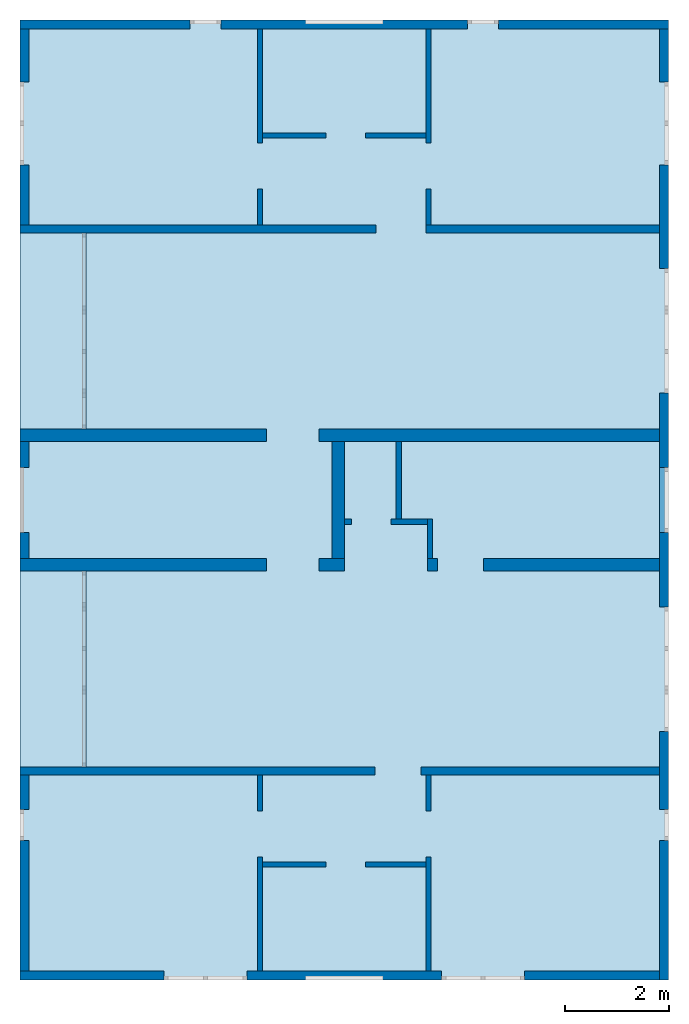
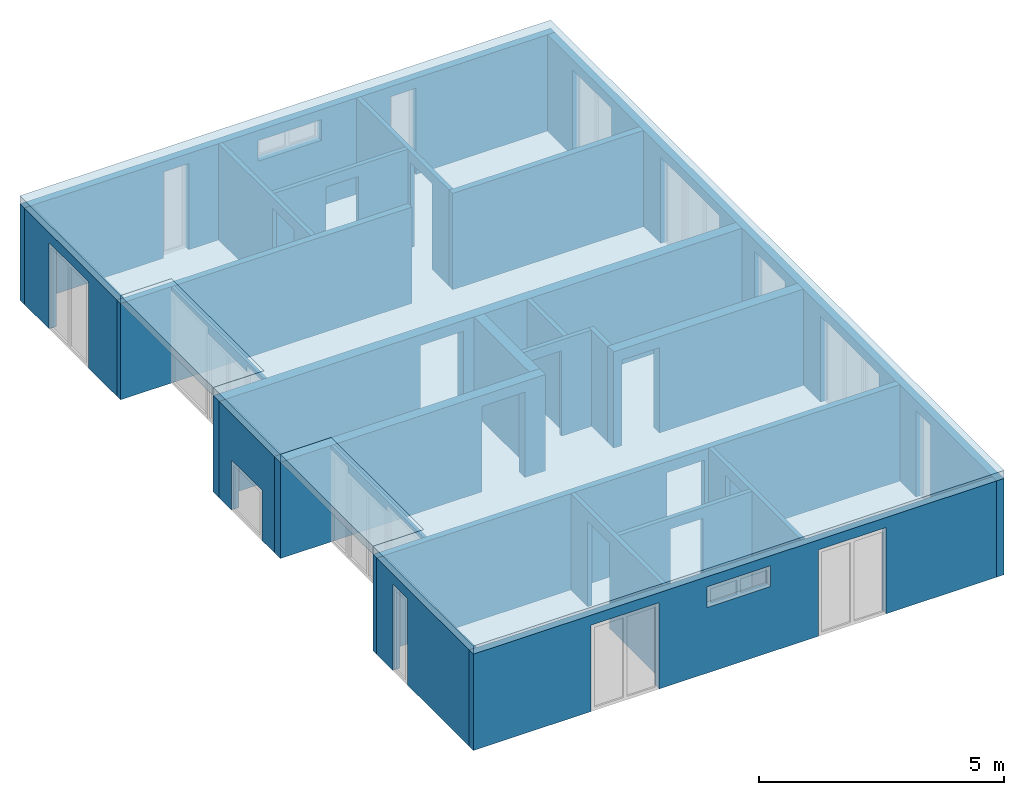
# One storey, part 1 of 8: 24 walls, 3 slabs, 33 openings.
"""IFC2X3 building model written with IfcOpenShell, lengths in millimetres."""

from ifc_helpers import new_model, entity, si_unit, converted_unit, frame, frame_2d, origin, origin_with_axes, place, context, project, spatial, polyline, rectangle, outline, extrude, material, layer, layer_set, layer_usage, element, save


model = new_model("IFC2X3")

# Units and contexts
model_context = context("Model", 3, precision=1e-05, world=origin())
plan_context = context("Plan", 3, precision=1e-05, world=origin())
ifc_project = project(units=[si_unit("LENGTHUNIT", "METRE", prefix="MILLI"), converted_unit("PLANEANGLEUNIT", "DEGREE", entity("IfcPlaneAngleMeasure", 0.0174532925199433), si_unit("PLANEANGLEUNIT", "RADIAN"), dimensions=[0, 0, 0, 0, 0, 0, 0]), si_unit("AREAUNIT", "SQUARE_METRE"), si_unit("VOLUMEUNIT", "CUBIC_METRE")], contexts=[model_context, plan_context])

# Building, storey
building_placement = place(None, origin())
building = spatial("IfcBuilding", under=ifc_project, at=building_placement, CompositionType="ELEMENT")
storey_placement = place(building_placement, frame((0.0, 0.0, 2900.0), z_axis=(0.0, 0.0, 1.0), x_axis=(1.0, 0.0, 0.0)))
storey = spatial("IfcBuildingStorey", under=building, at=storey_placement, Name="OG", CompositionType="ELEMENT", Elevation=2900.0)

# Slabs
ifc_material_1 = material(Name="B25")
ifc_layer_1 = layer(ifc_material_1, 200.0)
ifc_layer_set_1 = layer_set([ifc_layer_1])
ifc_layer_usage_1 = layer_usage(ifc_layer_set_1, "AXIS3", "POSITIVE", 0.0)
slab_1_placement = place(storey_placement, frame((21188.3517822139, 5708.43749999999, 2400.0), z_axis=(0.0, 0.0, 1.0), x_axis=(1.0, 0.0, 0.0)))
element("IfcSlab", 1, at=slab_1_placement, inside=storey, material=ifc_layer_usage_1, PredefinedType="FLOOR", context=model_context, shape_type="SweptSolid", body=[
    extrude(rectangle(XDim=3779.99999999999, YDim=1200.00000000373, at=frame_2d((600.0, -1890.00000000059), x_axis=(-9.85526533984635e-13, -1.0))), origin_with_axes(), (0.0, 0.0, 1.0), 200.0),
])
ifc_material_2 = material(Name="B25")
ifc_layer_2 = layer(ifc_material_2, 200.0)
ifc_layer_set_2 = layer_set([ifc_layer_2])
ifc_layer_usage_2 = layer_usage(ifc_layer_set_2, "AXIS3", "POSITIVE", 0.0)
slab_2_placement = place(storey_placement, frame((21188.3517822102, -811.5625, 2400.0), z_axis=(0.0, 0.0, 1.0), x_axis=(1.0, 0.0, 0.0)))
element("IfcSlab", 2, at=slab_2_placement, inside=storey, material=ifc_layer_usage_2, PredefinedType="FLOOR", context=model_context, shape_type="SweptSolid", body=[
    extrude(rectangle(XDim=3780.0, YDim=1200.0, at=frame_2d((600.000000001863, -1889.99999999941), x_axis=(9.85526533984634e-13, -1.0))), origin_with_axes(), (0.0, 0.0, 1.0), 200.0),
])
ifc_material_3 = material(Name="B25")
ifc_layer_3 = layer(ifc_material_3, 200.0)
ifc_layer_set_3 = layer_set([ifc_layer_3])
ifc_layer_usage_3 = layer_usage(ifc_layer_set_3, "AXIS3", "POSITIVE", 0.0)
slab_3_placement = place(storey_placement, frame((21188.3517822102, -8691.5625, 2400.0), z_axis=(0.0, 0.0, 1.0), x_axis=(1.0, 0.0, 0.0)))
element("IfcSlab", 3, at=slab_3_placement, inside=storey, material=ifc_layer_usage_3, PredefinedType="FLOOR", context=model_context, shape_type="SweptSolid", body=[
    extrude(outline(polyline([(3.72529029846191e-09, 18500.0), (3.72529029846191e-09, 14400.0), (1200.00000000373, 14400.0), (1200.00000000373, 10620.0), (0.0, 10620.0), (0.0, 7880.0), (1200.00000000373, 7880.0), (1200.00000000373, 4100.0), (3.72529029846191e-09, 4100.0), (3.72529029846191e-09, 0.0), (12500.0000000037, 0.0), (12500.0000000037, 18500.0), (3.72529029846191e-09, 18500.0)])), origin_with_axes(), (0.0, 0.0, 1.0), 200.0),
])

# Wall, opening
ifc_material_4 = material(Name="B25")
ifc_layer_4 = layer(ifc_material_4, 150.0)
ifc_layer_set_4 = layer_set([ifc_layer_4])
ifc_layer_usage_4 = layer_usage(ifc_layer_set_4, "AXIS2", "POSITIVE", 0.0)
wall_1_placement = place(storey_placement, frame((21188.3517822139, -4741.5625, 0.0), z_axis=(0.0, 0.0, 1.0), x_axis=(1.0, 0.0, 0.0)))
wall_1 = element("IfcWallStandardCase", 4, at=wall_1_placement, inside=storey, material=ifc_layer_usage_4, context=model_context, shape_type="SweptSolid", body=[
    extrude(rectangle(XDim=12324.9999999553, YDim=150.0, at=frame_2d((6162.49999997765, 75.0), x_axis=(1.0, 0.0))), origin_with_axes(), (0.0, 0.0, 1.0), 2400.0),
])
opening_1_placement = place(wall_1_placement, frame((6840.00089017584, 0.0, 0.0), z_axis=(0.0, 1.0, 0.0), x_axis=(0.0, 0.0, 1.0)))
element("IfcOpeningElement", 5, at=opening_1_placement, cuts=wall_1, ObjectType="Opening", context=model_context, shape_type="SweptSolid", body=[
    extrude(rectangle(XDim=2130.0, YDim=885.000000042997, at=frame_2d((1065.0, 442.500000021499), x_axis=(1.0, 0.0))), origin_with_axes(), (0.0, 0.0, 1.0), 150.0),
])

ifc_material_5 = material(Name="B25")
ifc_layer_5 = layer(ifc_material_5, 240.0)
ifc_layer_set_5 = layer_set([ifc_layer_5])
ifc_layer_usage_5 = layer_usage(ifc_layer_set_5, "AXIS2", "POSITIVE", 0.0)
wall_2_placement = place(storey_placement, frame((27438.3517822107, -571.5625, 0.0), z_axis=(0.0, 0.0, 1.0), x_axis=(-1.0, 0.0, 0.0)))
wall_2 = element("IfcWallStandardCase", 6, at=wall_2_placement, inside=storey, material=ifc_layer_usage_5, context=model_context, shape_type="SweptSolid", body=[
    extrude(rectangle(XDim=6250.0000000005, YDim=240.0, at=frame_2d((3125.00000000025, 120.0), x_axis=(1.0, 0.0))), origin_with_axes(), (0.0, 0.0, 1.0), 2400.0),
])
opening_2_placement = place(wall_2_placement, frame((490.000000000498, 0.0, 0.0), z_axis=(0.0, 1.0, 0.0), x_axis=(0.0, 0.0, 1.0)))
element("IfcOpeningElement", 7, at=opening_2_placement, cuts=wall_2, ObjectType="Opening", context=model_context, shape_type="SweptSolid", body=[
    extrude(rectangle(XDim=2130.0, YDim=1010.0, at=frame_2d((1065.0, 505.0), x_axis=(1.0, 0.0))), origin_with_axes(), (0.0, 0.0, 1.0), 240.0),
])

# Wall
ifc_material_6 = material(Name="B25")
ifc_layer_6 = layer(ifc_material_6, 150.0)
ifc_layer_set_6 = layer_set([ifc_layer_6])
ifc_layer_usage_6 = layer_usage(ifc_layer_set_6, "AXIS2", "POSITIVE", 0.0)
wall_3_placement = place(storey_placement, frame((21188.3517822139, 5708.4375, 0.0), z_axis=(0.0, 0.0, 1.0), x_axis=(1.0, 0.0, 0.0)))
element("IfcWallStandardCase", 8, at=wall_3_placement, inside=storey, material=ifc_layer_usage_6, context=model_context, shape_type="SweptSolid", body=[
    extrude(rectangle(XDim=6865.03345220687, YDim=150.0, at=frame_2d((3432.51672610344, 75.0), x_axis=(1.0, 0.0))), origin_with_axes(), (0.0, 0.0, 1.0), 2400.0),
])

# Wall, opening
ifc_material_7 = material(Name="B25")
ifc_layer_7 = layer(ifc_material_7, 240.0)
ifc_layer_set_7 = layer_set([ifc_layer_7])
ifc_layer_usage_7 = layer_usage(ifc_layer_set_7, "AXIS2", "POSITIVE", 0.0)
wall_4_placement = place(storey_placement, frame((33513.3517821692, 1928.4375, 0.0), z_axis=(0.0, 0.0, 1.0), x_axis=(-1.0, 0.0, 0.0)))
wall_4 = element("IfcWallStandardCase", 9, at=wall_4_placement, inside=storey, material=ifc_layer_usage_7, context=model_context, shape_type="SweptSolid", body=[
    extrude(rectangle(XDim=12324.9999999549, YDim=240.0, at=frame_2d((6162.49999997745, 120.0), x_axis=(1.0, 0.0))), origin_with_axes(), (0.0, 0.0, 1.0), 2400.0),
])
opening_3_placement = place(wall_4_placement, frame((6564.99999995902, 0.0, 0.0), z_axis=(0.0, 1.0, 0.0), x_axis=(0.0, 0.0, 1.0)))
element("IfcOpeningElement", 10, at=opening_3_placement, cuts=wall_4, ObjectType="Opening", context=model_context, shape_type="SweptSolid", body=[
    extrude(rectangle(XDim=2130.0, YDim=1010.0, at=frame_2d((1065.0, 505.0), x_axis=(1.0, 0.0))), origin_with_axes(), (0.0, 0.0, 1.0), 240.0),
])

ifc_material_8 = material(Name="GD")
ifc_layer_8 = layer(ifc_material_8, 100.0)
ifc_layer_set_8 = layer_set([ifc_layer_8])
ifc_layer_usage_8 = layer_usage(ifc_layer_set_8, "AXIS2", "POSITIVE", 0.0)
wall_5_placement = place(storey_placement, frame((29038.3517822102, 188.4375, 0.0), z_axis=(0.0, 0.0, 1.0), x_axis=(-1.0, 0.0, 0.0)))
wall_5 = element("IfcWallStandardCase", 11, at=wall_5_placement, inside=storey, material=ifc_layer_usage_8, context=model_context, shape_type="SweptSolid", body=[
    extrude(rectangle(XDim=1600.0, YDim=100.0, at=frame_2d((800.0, 50.0), x_axis=(1.0, 0.0))), origin_with_axes(), (0.0, 0.0, 1.0), 2400.0),
])
opening_4_placement = place(wall_5_placement, frame((700.0, 0.0, 0.0), z_axis=(0.0, 1.0, 0.0), x_axis=(0.0, 0.0, 1.0)))
element("IfcOpeningElement", 12, at=opening_4_placement, cuts=wall_5, ObjectType="Opening", context=model_context, shape_type="SweptSolid", body=[
    extrude(rectangle(XDim=2130.0, YDim=760.0, at=frame_2d((1065.0, 380.0), x_axis=(1.0, 0.0))), origin_with_axes(), (0.0, 0.0, 1.0), 100.0),
])

# Walls
ifc_material_9 = material(Name="GD")
ifc_layer_9 = layer(ifc_material_9, 100.0)
ifc_layer_set_9 = layer_set([ifc_layer_9])
ifc_layer_usage_9 = layer_usage(ifc_layer_set_9, "AXIS2", "POSITIVE", 0.0)
wall_6_placement = place(storey_placement, frame((28438.3517822102, 1688.4375, 0.0), z_axis=(0.0, 0.0, 1.0), x_axis=(0.0, -1.0, 0.0)))
element("IfcWallStandardCase", 13, at=wall_6_placement, inside=storey, material=ifc_layer_usage_9, context=model_context, shape_type="SweptSolid", body=[
    extrude(rectangle(XDim=1500.0, YDim=100.0, at=frame_2d((750.0, 50.0), x_axis=(1.0, 0.0))), origin_with_axes(), (0.0, 0.0, 1.0), 2400.0),
])
ifc_material_10 = material(Name="B25")
ifc_layer_10 = layer(ifc_material_10, 240.0)
ifc_layer_set_10 = layer_set([ifc_layer_10])
ifc_layer_usage_10 = layer_usage(ifc_layer_set_10, "AXIS2", "POSITIVE", 0.0)
wall_7_placement = place(storey_placement, frame((27198.3517822102, 1688.4375, 0.0), z_axis=(0.0, 0.0, 1.0), x_axis=(0.0, -1.0, 0.0)))
element("IfcWallStandardCase", 14, at=wall_7_placement, inside=storey, material=ifc_layer_usage_10, context=model_context, shape_type="SweptSolid", body=[
    extrude(rectangle(XDim=2260.0, YDim=240.0, at=frame_2d((1130.0, 120.0), x_axis=(1.0, 0.0))), origin_with_axes(), (0.0, 0.0, 1.0), 2400.0),
])
ifc_material_11 = material(Name="GD")
ifc_layer_11 = layer(ifc_material_11, 100.0)
ifc_layer_set_11 = layer_set([ifc_layer_11])
ifc_layer_usage_11 = layer_usage(ifc_layer_set_11, "AXIS2", "POSITIVE", 0.0)
wall_8_placement = place(storey_placement, frame((29138.3517822102, -571.5625, 0.0), z_axis=(0.0, 0.0, 1.0), x_axis=(0.0, 1.0, 0.0)))
element("IfcWallStandardCase", 15, at=wall_8_placement, inside=storey, material=ifc_layer_usage_11, context=model_context, shape_type="SweptSolid", body=[
    extrude(rectangle(XDim=760.0, YDim=100.0, at=frame_2d((380.0, 50.0), x_axis=(1.0, 0.0))), origin_with_axes(), (0.0, 0.0, 1.0), 2400.0),
])

# Wall, opening
ifc_material_12 = material(Name="GD")
ifc_layer_12 = layer(ifc_material_12, 100.0)
ifc_layer_set_12 = layer_set([ifc_layer_12])
ifc_layer_usage_12 = layer_usage(ifc_layer_set_12, "AXIS2", "POSITIVE", 0.0)
wall_9_placement = place(storey_placement, frame((25863.3517821692, -6516.58475652616, 0.0), z_axis=(0.0, 0.0, 1.0), x_axis=(1.0, 0.0, 0.0)))
wall_9 = element("IfcWallStandardCase", 16, at=wall_9_placement, inside=storey, material=ifc_layer_usage_12, context=model_context, shape_type="SweptSolid", body=[
    extrude(rectangle(XDim=3150.0, YDim=100.0, at=frame_2d((1575.0, 50.0), x_axis=(1.0, 0.0))), origin_with_axes(), (0.0, 0.0, 1.0), 2400.0),
])
opening_5_placement = place(wall_9_placement, frame((1224.99999997392, 0.0, 0.0), z_axis=(0.0, 1.0, 0.0), x_axis=(0.0, 0.0, 1.0)))
element("IfcOpeningElement", 17, at=opening_5_placement, cuts=wall_9, ObjectType="Opening", context=model_context, shape_type="SweptSolid", body=[
    extrude(rectangle(XDim=2130.0, YDim=759.999109685581, at=frame_2d((1065.0, 379.999554842791), x_axis=(1.0, 0.0))), origin_with_axes(), (0.0, 0.0, 1.0), 100.0),
])

ifc_material_13 = material(Name="B25")
ifc_layer_13 = layer(ifc_material_13, 175.0)
ifc_layer_set_13 = layer_set([ifc_layer_13])
ifc_layer_usage_13 = layer_usage(ifc_layer_set_13, "AXIS2", "POSITIVE", 0.0)
wall_10_placement = place(storey_placement, frame((21188.3517822139, -4741.5625, 0.0), z_axis=(0.0, 0.0, 1.0), x_axis=(0.0, -1.0, 0.0)))
wall_10 = element("IfcWallStandardCase", 18, at=wall_10_placement, inside=storey, material=ifc_layer_usage_13, context=model_context, shape_type="SweptSolid", body=[
    extrude(rectangle(XDim=3775.0, YDim=175.0, at=frame_2d((1887.5, 87.5), x_axis=(1.0, 0.0))), origin_with_axes(), (0.0, 0.0, 1.0), 2400.0),
])
opening_6_placement = place(wall_10_placement, frame((660.000000000001, 0.0, 0.0), z_axis=(0.0, 1.0, 0.0), x_axis=(0.0, 0.0, 1.0)))
element("IfcOpeningElement", 19, at=opening_6_placement, cuts=wall_10, ObjectType="Opening", context=model_context, shape_type="SweptSolid", body=[
    extrude(rectangle(XDim=2150.0, YDim=600.0, at=frame_2d((1075.0, 300.0), x_axis=(1.0, 0.0))), origin_with_axes(), (0.0, 0.0, 1.0), 175.0),
])

ifc_material_14 = material(Name="GD")
ifc_layer_14 = layer(ifc_material_14, 100.0)
ifc_layer_set_14 = layer_set([ifc_layer_14])
ifc_layer_usage_14 = layer_usage(ifc_layer_set_14, "AXIS2", "POSITIVE", 0.0)
wall_11_placement = place(storey_placement, frame((25763.3517821692, -4741.56249999999, 0.0), z_axis=(0.0, 0.0, 1.0), x_axis=(0.0, -1.0, 0.0)))
wall_11 = element("IfcWallStandardCase", 20, at=wall_11_placement, inside=storey, material=ifc_layer_usage_14, context=model_context, shape_type="SweptSolid", body=[
    extrude(rectangle(XDim=3775.00000000001, YDim=100.0, at=frame_2d((1887.5, 50.0), x_axis=(1.0, 0.0))), origin_with_axes(), (0.0, 0.0, 1.0), 2400.0),
])
opening_7_placement = place(wall_11_placement, frame((690.022256533231, 0.0, 0.0), z_axis=(0.0, 1.0, 0.0), x_axis=(0.0, 0.0, 1.0)))
element("IfcOpeningElement", 21, at=opening_7_placement, cuts=wall_11, ObjectType="Opening", context=model_context, shape_type="SweptSolid", body=[
    extrude(rectangle(XDim=2130.0, YDim=885.000000000514, at=frame_2d((1065.0, 442.500000000257), x_axis=(1.0, 0.0))), origin_with_axes(), (0.0, 0.0, 1.0), 100.0),
])

ifc_material_15 = material(Name="GD")
ifc_layer_15 = layer(ifc_material_15, 100.0)
ifc_layer_set_15 = layer_set([ifc_layer_15])
ifc_layer_usage_15 = layer_usage(ifc_layer_set_15, "AXIS2", "POSITIVE", 0.0)
wall_12_placement = place(storey_placement, frame((29113.3517821692, -8516.5625, 0.0), z_axis=(0.0, 0.0, 1.0), x_axis=(0.0, 1.0, 0.0)))
wall_12 = element("IfcWallStandardCase", 22, at=wall_12_placement, inside=storey, material=ifc_layer_usage_15, context=model_context, shape_type="SweptSolid", body=[
    extrude(rectangle(XDim=3775.0, YDim=100.0, at=frame_2d((1887.5, 50.0), x_axis=(1.0, 0.0))), origin_with_axes(), (0.0, 0.0, 1.0), 2400.0),
])
opening_8_placement = place(wall_12_placement, frame((2199.97774346626, 0.0, 0.0), z_axis=(0.0, 1.0, 0.0), x_axis=(0.0, 0.0, 1.0)))
element("IfcOpeningElement", 23, at=opening_8_placement, cuts=wall_12, ObjectType="Opening", context=model_context, shape_type="SweptSolid", body=[
    extrude(rectangle(XDim=2130.0, YDim=885.000000000514, at=frame_2d((1065.0, 442.500000000257), x_axis=(1.0, 0.0))), origin_with_axes(), (0.0, 0.0, 1.0), 100.0),
])

# Wall, openings
ifc_material_16 = material(Name="B25")
ifc_layer_16 = layer(ifc_material_16, 175.0)
ifc_layer_set_16 = layer_set([ifc_layer_16])
ifc_layer_usage_16 = layer_usage(ifc_layer_set_16, "AXIS2", "POSITIVE", 0.0)
wall_13_placement = place(storey_placement, frame((21188.3517822139, -8691.5625, 0.0), z_axis=(0.0, 0.0, 1.0), x_axis=(1.0, 0.0, 0.0)))
wall_13 = element("IfcWallStandardCase", 24, at=wall_13_placement, inside=storey, material=ifc_layer_usage_16, context=model_context, shape_type="SweptSolid", body=[
    extrude(rectangle(XDim=12324.9999999553, YDim=175.0, at=frame_2d((6162.49999997765, 87.5), x_axis=(1.0, 0.0))), origin_with_axes(), (0.0, 0.0, 1.0), 2400.0),
])
opening_9_placement = place(wall_13_placement, frame((5499.99999998852, 0.0, 1635.0), z_axis=(0.0, 1.0, 0.0), x_axis=(0.0, 0.0, 1.0)))
element("IfcOpeningElement", 25, at=opening_9_placement, cuts=wall_13, ObjectType="Opening", context=model_context, shape_type="SweptSolid", body=[
    extrude(rectangle(XDim=515.0, YDim=1500.0, at=frame_2d((257.5, 750.0), x_axis=(1.0, 0.0))), origin_with_axes(), (0.0, 0.0, 1.0), 175.0),
])
opening_10_placement = place(wall_13_placement, frame((2775.00178047279, 0.0, 0.0), z_axis=(0.0, 1.0, 0.0), x_axis=(0.0, 0.0, 1.0)))
element("IfcOpeningElement", 26, at=opening_10_placement, cuts=wall_13, ObjectType="Opening", context=model_context, shape_type="SweptSolid", body=[
    extrude(rectangle(XDim=2150.0, YDim=1600.0, at=frame_2d((1075.0, 800.0), x_axis=(1.0, 0.0))), origin_with_axes(), (0.0, 0.0, 1.0), 175.0),
])
opening_11_placement = place(wall_13_placement, frame((8124.9982195274, 0.0, 0.0), z_axis=(0.0, 1.0, 0.0), x_axis=(0.0, 0.0, 1.0)))
element("IfcOpeningElement", 27, at=opening_11_placement, cuts=wall_13, ObjectType="Opening", context=model_context, shape_type="SweptSolid", body=[
    extrude(rectangle(XDim=2150.0, YDim=1600.0, at=frame_2d((1075.0, 800.0), x_axis=(1.0, 0.0))), origin_with_axes(), (0.0, 0.0, 1.0), 175.0),
])

# Wall, opening
ifc_material_17 = material(Name="B25")
ifc_layer_17 = layer(ifc_material_17, 240.0)
ifc_layer_set_17 = layer_set([ifc_layer_17])
ifc_layer_usage_17 = layer_usage(ifc_layer_set_17, "AXIS2", "POSITIVE", 0.0)
wall_14_placement = place(storey_placement, frame((33513.3517821655, -571.5625, 0.0), z_axis=(0.0, 0.0, 1.0), x_axis=(-1.0, 0.0, 0.0)))
wall_14 = element("IfcWallStandardCase", 28, at=wall_14_placement, inside=storey, material=ifc_layer_usage_17, context=model_context, shape_type="SweptSolid", body=[
    extrude(rectangle(XDim=4474.9999999553, YDim=240.0, at=frame_2d((2237.49999997765, 120.0), x_axis=(1.0, 0.0))), origin_with_axes(), (0.0, 0.0, 1.0), 2400.0),
])
opening_12_placement = place(wall_14_placement, frame((3389.9999999553, 0.0, 0.0), z_axis=(0.0, 1.0, 0.0), x_axis=(0.0, 0.0, 1.0)))
element("IfcOpeningElement", 29, at=opening_12_placement, cuts=wall_14, ObjectType="Opening", context=model_context, shape_type="SweptSolid", body=[
    extrude(rectangle(XDim=2130.0, YDim=885.0, at=frame_2d((1065.0, 442.5), x_axis=(1.0, 0.0))), origin_with_axes(), (0.0, 0.0, 1.0), 240.0),
])

# Wall
ifc_material_18 = material(Name="B25")
ifc_layer_18 = layer(ifc_material_18, 150.0)
ifc_layer_set_18 = layer_set([ifc_layer_18])
ifc_layer_usage_18 = layer_usage(ifc_layer_set_18, "AXIS2", "POSITIVE", 0.0)
wall_15_placement = place(storey_placement, frame((29013.3517822549, 5708.4375, 0.0), z_axis=(0.0, 0.0, 1.0), x_axis=(1.0, 0.0, 0.0)))
element("IfcWallStandardCase", 30, at=wall_15_placement, inside=storey, material=ifc_layer_usage_18, context=model_context, shape_type="SweptSolid", body=[
    extrude(rectangle(XDim=4499.99999991432, YDim=150.0, at=frame_2d((2249.99999995716, 75.0), x_axis=(1.0, 0.0))), origin_with_axes(), (0.0, 0.0, 1.0), 2400.0),
])

# Wall, opening
ifc_material_19 = material(Name="GD")
ifc_layer_19 = layer(ifc_material_19, 100.0)
ifc_layer_set_19 = layer_set([ifc_layer_19])
ifc_layer_usage_19 = layer_usage(ifc_layer_set_19, "AXIS2", "POSITIVE", 0.0)
wall_16_placement = place(storey_placement, frame((25763.3517822549, 9633.4375, 0.0), z_axis=(0.0, 0.0, 1.0), x_axis=(0.0, -1.0, 0.0)))
wall_16 = element("IfcWallStandardCase", 31, at=wall_16_placement, inside=storey, material=ifc_layer_usage_19, context=model_context, shape_type="SweptSolid", body=[
    extrude(rectangle(XDim=3775.0, YDim=100.0, at=frame_2d((1887.5, 50.0), x_axis=(1.0, 0.0))), origin_with_axes(), (0.0, 0.0, 1.0), 2400.0),
])
opening_13_placement = place(wall_16_placement, frame((2199.99999999615, 0.0, 0.0), z_axis=(0.0, 1.0, 0.0), x_axis=(0.0, 0.0, 1.0)))
element("IfcOpeningElement", 32, at=opening_13_placement, cuts=wall_16, ObjectType="Opening", context=model_context, shape_type="SweptSolid", body=[
    extrude(rectangle(XDim=2130.0, YDim=885.000000000514, at=frame_2d((1065.0, 442.500000000257), x_axis=(1.0, 0.0))), origin_with_axes(), (0.0, 0.0, 1.0), 100.0),
])

ifc_material_20 = material(Name="GD")
ifc_layer_20 = layer(ifc_material_20, 99.9999999180436)
ifc_layer_set_20 = layer_set([ifc_layer_20])
ifc_layer_usage_20 = layer_usage(ifc_layer_set_20, "AXIS2", "POSITIVE", 0.0)
wall_17_placement = place(storey_placement, frame((29113.3517821729, 5858.4375, 0.0), z_axis=(0.0, 0.0, 1.0), x_axis=(0.0, 1.0, 0.0)))
wall_17 = element("IfcWallStandardCase", 33, at=wall_17_placement, inside=storey, material=ifc_layer_usage_20, context=model_context, shape_type="SweptSolid", body=[
    extrude(rectangle(XDim=3775.0, YDim=99.9999999180436, at=frame_2d((1887.5, 49.9999999590218), x_axis=(1.0, 0.0))), origin_with_axes(), (0.0, 0.0, 1.0), 2400.0),
])
opening_14_placement = place(wall_17_placement, frame((690.000000003335, 0.0, 0.0), z_axis=(0.0, 1.0, 0.0), x_axis=(0.0, 0.0, 1.0)))
element("IfcOpeningElement", 34, at=opening_14_placement, cuts=wall_17, ObjectType="Opening", context=model_context, shape_type="SweptSolid", body=[
    extrude(rectangle(XDim=2130.0, YDim=885.000000000514, at=frame_2d((1065.0, 442.500000000257), x_axis=(1.0, 0.0))), origin_with_axes(), (0.0, 0.0, 1.0), 99.9999999180436),
])

# Wall, openings
ifc_material_21 = material(Name="B25")
ifc_layer_21 = layer(ifc_material_21, 175.0)
ifc_layer_set_21 = layer_set([ifc_layer_21])
ifc_layer_usage_21 = layer_usage(ifc_layer_set_21, "AXIS2", "POSITIVE", 0.0)
wall_18_placement = place(storey_placement, frame((33688.3517822139, 9808.4375, 0.0), z_axis=(0.0, 0.0, 1.0), x_axis=(-1.0, 0.0, 0.0)))
wall_18 = element("IfcWallStandardCase", 35, at=wall_18_placement, inside=storey, material=ifc_layer_usage_21, context=model_context, shape_type="SweptSolid", body=[
    extrude(rectangle(XDim=12500.0, YDim=175.0, at=frame_2d((6250.0, 87.5), x_axis=(1.0, 0.0))), origin_with_axes(), (0.0, 0.0, 1.0), 2400.0),
])
opening_15_placement = place(wall_18_placement, frame((3274.9999999553, 0.0, 0.0), z_axis=(0.0, 1.0, 0.0), x_axis=(0.0, 0.0, 1.0)))
element("IfcOpeningElement", 36, at=opening_15_placement, cuts=wall_18, ObjectType="Opening", context=model_context, shape_type="SweptSolid", body=[
    extrude(rectangle(XDim=2150.0, YDim=600.0, at=frame_2d((1075.0, 300.0), x_axis=(1.0, 0.0))), origin_with_axes(), (0.0, 0.0, 1.0), 175.0),
])
opening_16_placement = place(wall_18_placement, frame((5500.00000001148, 0.0, 1635.0), z_axis=(0.0, 1.0, 0.0), x_axis=(0.0, 0.0, 1.0)))
element("IfcOpeningElement", 37, at=opening_16_placement, cuts=wall_18, ObjectType="Opening", context=model_context, shape_type="SweptSolid", body=[
    extrude(rectangle(XDim=515.0, YDim=1500.0, at=frame_2d((257.5, 750.0), x_axis=(1.0, 0.0))), origin_with_axes(), (0.0, 0.0, 1.0), 175.0),
])
opening_17_placement = place(wall_18_placement, frame((8625.0000000447, 0.0, 0.0), z_axis=(0.0, 1.0, 0.0), x_axis=(0.0, 0.0, 1.0)))
element("IfcOpeningElement", 38, at=opening_17_placement, cuts=wall_18, ObjectType="Opening", context=model_context, shape_type="SweptSolid", body=[
    extrude(rectangle(XDim=2150.0, YDim=600.0, at=frame_2d((1075.0, 300.0), x_axis=(1.0, 0.0))), origin_with_axes(), (0.0, 0.0, 1.0), 175.0),
])

# Wall, opening
ifc_material_22 = material(Name="GD")
ifc_layer_22 = layer(ifc_material_22, 100.0)
ifc_layer_set_22 = layer_set([ifc_layer_22])
ifc_layer_usage_22 = layer_usage(ifc_layer_set_22, "AXIS2", "POSITIVE", 0.0)
wall_19_placement = place(storey_placement, frame((25863.3517822549, 7533.4375, 0.0), z_axis=(0.0, 0.0, 1.0), x_axis=(1.0, 0.0, 0.0)))
wall_19 = element("IfcWallStandardCase", 39, at=wall_19_placement, inside=storey, material=ifc_layer_usage_22, context=model_context, shape_type="SweptSolid", body=[
    extrude(rectangle(XDim=3150.0, YDim=100.0, at=frame_2d((1575.0, 50.0), x_axis=(1.0, 0.0))), origin_with_axes(), (0.0, 0.0, 1.0), 2400.0),
])
opening_18_placement = place(wall_19_placement, frame((1224.98130458333, 0.0, 0.0), z_axis=(0.0, 1.0, 0.0), x_axis=(0.0, 0.0, 1.0)))
element("IfcOpeningElement", 40, at=opening_18_placement, cuts=wall_19, ObjectType="Opening", context=model_context, shape_type="SweptSolid", body=[
    extrude(rectangle(XDim=2130.0, YDim=759.999109685581, at=frame_2d((1065.0, 379.999554842791), x_axis=(1.0, 0.0))), origin_with_axes(), (0.0, 0.0, 1.0), 100.0),
])

ifc_material_23 = material(Name="B25")
ifc_layer_23 = layer(ifc_material_23, 175.0)
ifc_layer_set_23 = layer_set([ifc_layer_23])
ifc_layer_usage_23 = layer_usage(ifc_layer_set_23, "AXIS2", "POSITIVE", 0.0)
wall_20_placement = place(storey_placement, frame((21188.3517822139, 9633.4375, 0.0), z_axis=(0.0, 0.0, 1.0), x_axis=(0.0, -1.0, 0.0)))
wall_20 = element("IfcWallStandardCase", 41, at=wall_20_placement, inside=storey, material=ifc_layer_usage_23, context=model_context, shape_type="SweptSolid", body=[
    extrude(rectangle(XDim=3775.0, YDim=175.0, at=frame_2d((1887.5, 87.5), x_axis=(1.0, 0.0))), origin_with_axes(), (0.0, 0.0, 1.0), 2400.0),
])
opening_19_placement = place(wall_20_placement, frame((1015.0, 0.0, 0.0), z_axis=(0.0, 1.0, 0.0), x_axis=(0.0, 0.0, 1.0)))
element("IfcOpeningElement", 42, at=opening_19_placement, cuts=wall_20, ObjectType="Opening", context=model_context, shape_type="SweptSolid", body=[
    extrude(rectangle(XDim=2150.0, YDim=1600.0, at=frame_2d((1075.0, 800.0), x_axis=(1.0, 0.0))), origin_with_axes(), (0.0, 0.0, 1.0), 175.0),
])

# Wall, openings
ifc_material_24 = material(Name="B25")
ifc_layer_24 = layer(ifc_material_24, 175.000000044703)
ifc_layer_set_24 = layer_set([ifc_layer_24])
ifc_layer_usage_24 = layer_usage(ifc_layer_set_24, "AXIS2", "POSITIVE", 0.0)
wall_21_placement = place(storey_placement, frame((33688.3517822139, -8691.5625, 0.0), z_axis=(0.0, 0.0, 1.0), x_axis=(0.0, 1.0, 0.0)))
wall_21 = element("IfcWallStandardCase", 43, at=wall_21_placement, inside=storey, material=ifc_layer_usage_24, context=model_context, shape_type="SweptSolid", body=[
    extrude(rectangle(XDim=18325.0, YDim=175.000000044703, at=frame_2d((9162.5, 87.5000000223517), x_axis=(1.0, 0.0))), origin_with_axes(), (0.0, 0.0, 1.0), 2400.0),
])
opening_20_placement = place(wall_21_placement, frame((2690.0, 0.0, 0.0), z_axis=(0.0, 1.0, 0.0), x_axis=(0.0, 0.0, 1.0)))
element("IfcOpeningElement", 44, at=opening_20_placement, cuts=wall_21, ObjectType="Opening", context=model_context, shape_type="SweptSolid", body=[
    extrude(rectangle(XDim=2150.0, YDim=600.0, at=frame_2d((1075.0, 300.0), x_axis=(1.0, 0.0))), origin_with_axes(), (0.0, 0.0, 1.0), 175.000000044703),
])
opening_21_placement = place(wall_21_placement, frame((5590.0, 0.0, 0.0), z_axis=(0.0, 1.0, 0.0), x_axis=(0.0, 0.0, 1.0)))
element("IfcOpeningElement", 45, at=opening_21_placement, cuts=wall_21, ObjectType="Opening", context=model_context, shape_type="SweptSolid", body=[
    extrude(rectangle(XDim=2150.0, YDim=1600.0, at=frame_2d((1075.0, 800.0), x_axis=(1.0, 0.0))), origin_with_axes(), (0.0, 0.0, 1.0), 175.000000044703),
])
opening_22_placement = place(wall_21_placement, frame((15710.0, 0.0, 0.0), z_axis=(0.0, 1.0, 0.0), x_axis=(0.0, 0.0, 1.0)))
element("IfcOpeningElement", 46, at=opening_22_placement, cuts=wall_21, ObjectType="Opening", context=model_context, shape_type="SweptSolid", body=[
    extrude(rectangle(XDim=2150.0, YDim=1600.0, at=frame_2d((1075.0, 800.0), x_axis=(1.0, 0.0))), origin_with_axes(), (0.0, 0.0, 1.0), 175.000000044703),
])
opening_23_placement = place(wall_21_placement, frame((8625.0, 1.86264514923096e-09, 875.0), z_axis=(0.0, 1.0, 0.0), x_axis=(0.0, 0.0, 1.0)))
element("IfcOpeningElement", 47, at=opening_23_placement, cuts=wall_21, ObjectType="Opening", context=model_context, shape_type="SweptSolid", body=[
    extrude(rectangle(XDim=1250.0, YDim=1250.0, at=frame_2d((625.0, 625.0), x_axis=(1.0, 0.0))), origin_with_axes(), (0.0, 0.0, 1.0), 175.000000044703),
])
opening_24_placement = place(wall_21_placement, frame((4790.0, 0.0, 0.0), z_axis=(0.0, 1.0, 0.0), x_axis=(0.0, 0.0, 1.0)))
element("IfcOpeningElement", 48, at=opening_24_placement, cuts=wall_21, ObjectType="Opening", context=model_context, shape_type="SweptSolid", body=[
    extrude(rectangle(XDim=2150.0, YDim=800.0, at=frame_2d((1075.0, 400.0), x_axis=(1.0, 0.0))), origin_with_axes(), (0.0, 0.0, 1.0), 175.000000044703),
])
opening_25_placement = place(wall_21_placement, frame((12910.0, 0.0, 0.0), z_axis=(0.0, 1.0, 0.0), x_axis=(0.0, 0.0, 1.0)))
element("IfcOpeningElement", 49, at=opening_25_placement, cuts=wall_21, ObjectType="Opening", context=model_context, shape_type="SweptSolid", body=[
    extrude(rectangle(XDim=2150.0, YDim=800.0, at=frame_2d((1075.0, 400.0), x_axis=(1.0, 0.0))), origin_with_axes(), (0.0, 0.0, 1.0), 175.000000044703),
])
opening_26_placement = place(wall_21_placement, frame((11310.0, 0.0, 0.0), z_axis=(0.0, 1.0, 0.0), x_axis=(0.0, 0.0, 1.0)))
element("IfcOpeningElement", 50, at=opening_26_placement, cuts=wall_21, ObjectType="Opening", context=model_context, shape_type="SweptSolid", body=[
    extrude(rectangle(XDim=2150.0, YDim=1600.0, at=frame_2d((1075.0, 800.0), x_axis=(1.0, 0.0))), origin_with_axes(), (0.0, 0.0, 1.0), 175.000000044703),
])

# Wall, opening
ifc_material_25 = material(Name="B25")
ifc_layer_25 = layer(ifc_material_25, 175.0)
ifc_layer_set_25 = layer_set([ifc_layer_25])
ifc_layer_usage_25 = layer_usage(ifc_layer_set_25, "AXIS2", "POSITIVE", 0.0)
wall_22_placement = place(storey_placement, frame((21188.3517822139, 1688.4375, 0.0), z_axis=(0.0, 0.0, 1.0), x_axis=(-1.64835853914244e-12, -1.0, 0.0)))
wall_22 = element("IfcWallStandardCase", 51, at=wall_22_placement, inside=storey, material=ifc_layer_usage_25, context=model_context, shape_type="SweptSolid", body=[
    extrude(rectangle(XDim=2260.0, YDim=175.0, at=frame_2d((1130.0, 87.5), x_axis=(1.0, 0.0))), origin_with_axes(), (0.0, 0.0, 1.0), 2400.0),
])
opening_27_placement = place(wall_22_placement, frame((505.000000000001, -8.54925019665361e-13, 0.0), z_axis=(0.0, 1.0, 0.0), x_axis=(0.0, 0.0, 1.0)))
element("IfcOpeningElement", 52, at=opening_27_placement, cuts=wall_22, ObjectType="Opening", context=model_context, shape_type="SweptSolid", body=[
    extrude(rectangle(XDim=1250.0, YDim=1250.0, at=frame_2d((625.0, 625.0), x_axis=(1.0, 0.0))), origin_with_axes(), (0.0, 0.0, 1.0), 175.0),
])

# Wall, openings
ifc_material_26 = material(Name="glas")
ifc_layer_26 = layer(ifc_material_26, 70.0)
ifc_layer_set_26 = layer_set([ifc_layer_26])
ifc_layer_usage_26 = layer_usage(ifc_layer_set_26, "AXIS2", "POSITIVE", 0.0)
wall_23_placement = place(storey_placement, frame((22458.3517822139, 1928.4375, 0.0), z_axis=(0.0, 0.0, 1.0), x_axis=(0.0, 1.0, 0.0)))
wall_23 = element("IfcWallStandardCase", 53, at=wall_23_placement, inside=storey, material=ifc_layer_usage_26, context=model_context, shape_type="SweptSolid", body=[
    extrude(rectangle(XDim=3780.0, YDim=70.0, at=frame_2d((1890.0, 35.0), x_axis=(1.0, 0.0))), origin_with_axes(), (0.0, 0.0, 1.0), 2400.0),
])
opening_28_placement = place(wall_23_placement, frame((2290.0, 0.0, 0.0), z_axis=(0.0, 1.0, 0.0), x_axis=(0.0, 0.0, 1.0)))
element("IfcOpeningElement", 54, at=opening_28_placement, cuts=wall_23, ObjectType="Opening", context=model_context, shape_type="SweptSolid", body=[
    extrude(rectangle(XDim=2300.0, YDim=1490.0, at=frame_2d((1150.0, 745.0), x_axis=(1.0, 0.0))), origin_with_axes(), (0.0, 0.0, 1.0), 70.0),
])
opening_29_placement = place(wall_23_placement, frame((0.0, 0.0, 0.0), z_axis=(0.0, 1.0, 0.0), x_axis=(0.0, 0.0, 1.0)))
element("IfcOpeningElement", 55, at=opening_29_placement, cuts=wall_23, ObjectType="Opening", context=model_context, shape_type="SweptSolid", body=[
    extrude(rectangle(XDim=2300.0, YDim=689.999999999996, at=frame_2d((1150.0, 344.999999999998), x_axis=(1.0, 0.0))), origin_with_axes(), (0.0, 0.0, 1.0), 70.0),
])
opening_30_placement = place(wall_23_placement, frame((689.999999999996, 0.0, 0.0), z_axis=(0.0, 1.0, 0.0), x_axis=(0.0, 0.0, 1.0)))
element("IfcOpeningElement", 56, at=opening_30_placement, cuts=wall_23, ObjectType="Opening", context=model_context, shape_type="SweptSolid", body=[
    extrude(rectangle(XDim=2150.0, YDim=1600.0, at=frame_2d((1075.0, 800.0), x_axis=(1.0, 0.0))), origin_with_axes(), (0.0, 0.0, 1.0), 70.0),
])

ifc_material_27 = material(Name="glas")
ifc_layer_27 = layer(ifc_material_27, 70.0)
ifc_layer_set_27 = layer_set([ifc_layer_27])
ifc_layer_usage_27 = layer_usage(ifc_layer_set_27, "AXIS2", "POSITIVE", 0.0)
wall_24_placement = place(storey_placement, frame((22458.3517822139, -4591.5625, 0.0), z_axis=(0.0, 0.0, 1.0), x_axis=(0.0, 1.0, 0.0)))
wall_24 = element("IfcWallStandardCase", 57, at=wall_24_placement, inside=storey, material=ifc_layer_usage_27, context=model_context, shape_type="SweptSolid", body=[
    extrude(rectangle(XDim=3780.0, YDim=70.0, at=frame_2d((1890.0, 35.0), x_axis=(1.0, 0.0))), origin_with_axes(), (0.0, 0.0, 1.0), 2400.0),
])
opening_31_placement = place(wall_24_placement, frame((1490.0, 0.0, 0.0), z_axis=(0.0, 1.0, 0.0), x_axis=(0.0, 0.0, 1.0)))
element("IfcOpeningElement", 58, at=opening_31_placement, cuts=wall_24, ObjectType="Opening", context=model_context, shape_type="SweptSolid", body=[
    extrude(rectangle(XDim=2150.0, YDim=1600.0, at=frame_2d((1075.0, 800.0), x_axis=(1.0, 0.0))), origin_with_axes(), (0.0, 0.0, 1.0), 70.0),
])
opening_32_placement = place(wall_24_placement, frame((3090.0, 0.0, 0.0), z_axis=(0.0, 1.0, 0.0), x_axis=(0.0, 0.0, 1.0)))
element("IfcOpeningElement", 59, at=opening_32_placement, cuts=wall_24, ObjectType="Opening", context=model_context, shape_type="SweptSolid", body=[
    extrude(rectangle(XDim=2300.0, YDim=689.999999999996, at=frame_2d((1150.0, 344.999999999998), x_axis=(1.0, 0.0))), origin_with_axes(), (0.0, 0.0, 1.0), 70.0),
])
opening_33_placement = place(wall_24_placement, frame((0.0, 0.0, 0.0), z_axis=(0.0, 1.0, 0.0), x_axis=(0.0, 0.0, 1.0)))
element("IfcOpeningElement", 60, at=opening_33_placement, cuts=wall_24, ObjectType="Opening", context=model_context, shape_type="SweptSolid", body=[
    extrude(rectangle(XDim=2300.0, YDim=1490.0, at=frame_2d((1150.0, 745.0), x_axis=(1.0, 0.0))), origin_with_axes(), (0.0, 0.0, 1.0), 70.0),
])

save(model, "model.ifc")
